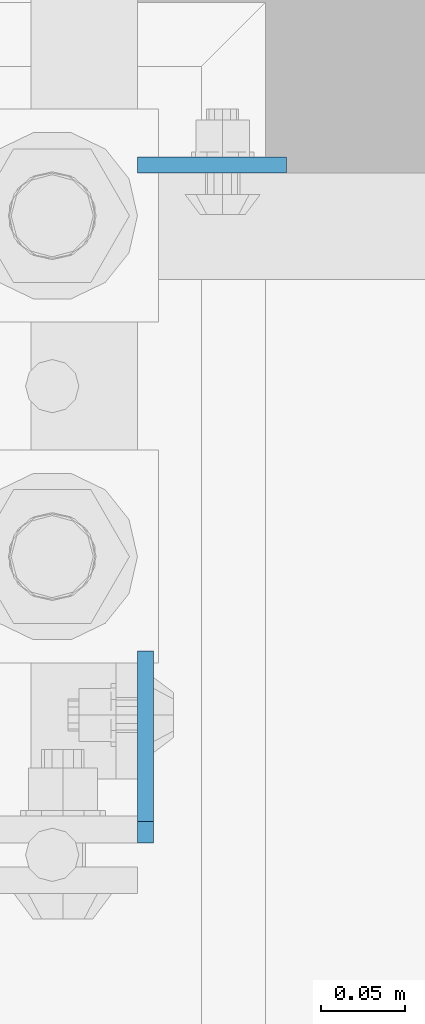
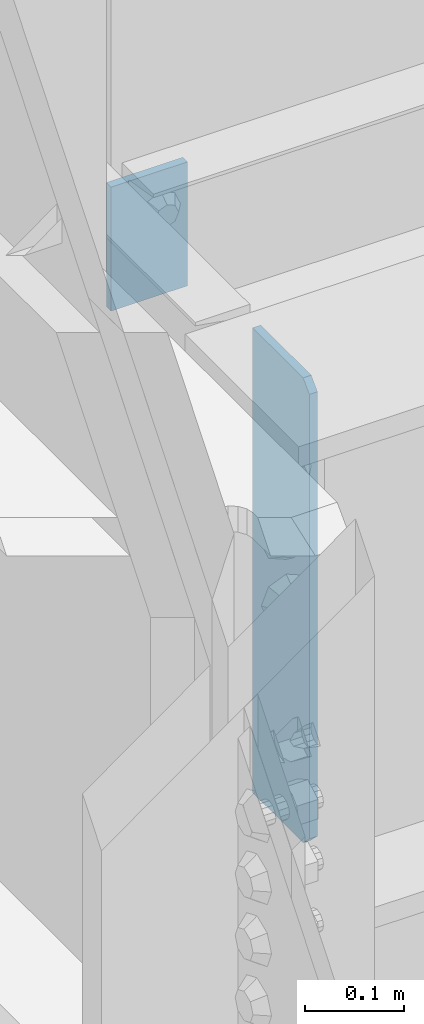
# One storey, part 1546 of 1876: 2 plates, 2 elements without a shape of their own.
"""IFC2X3 building model written with IfcOpenShell, lengths in millimetres."""

from ifc_helpers import new_model, si_unit, frame, origin_with_axes, place, context, subcontext, project, spatial, faceted_brep, material, type_object, element, aggregate, save


model = new_model("IFC2X3")

# Units and contexts
model_context = context("Model", 3, precision=1e-05, world=origin_with_axes())
body_context = subcontext(model_context, "Body", "Model", "MODEL_VIEW")
ifc_project = project(units=[si_unit("LENGTHUNIT", "METRE", prefix="MILLI"), si_unit("AREAUNIT", "SQUARE_METRE"), si_unit("VOLUMEUNIT", "CUBIC_METRE"), si_unit("MASSUNIT", "GRAM", prefix="KILO"), si_unit("TIMEUNIT", "SECOND"), si_unit("PLANEANGLEUNIT", "RADIAN"), si_unit("SOLIDANGLEUNIT", "STERADIAN"), si_unit("THERMODYNAMICTEMPERATUREUNIT", "DEGREE_CELSIUS"), si_unit("LUMINOUSINTENSITYUNIT", "LUMEN")], contexts=[model_context])

# Site, building, storey
site_placement = place(None, origin_with_axes())
site = spatial("IfcSite", under=ifc_project, at=site_placement, CompositionType="ELEMENT")
building_placement = place(site_placement, origin_with_axes())
building = spatial("IfcBuilding", under=site, at=building_placement, Name="Undefined", CompositionType="ELEMENT")
storey_placement = place(building_placement, origin_with_axes())
storey = spatial("IfcBuildingStorey", under=building, at=storey_placement, Name="Undefined", CompositionType="ELEMENT", Elevation=0.0)

# Assembly, plate
assembly_1_placement = place(storey_placement, origin_with_axes())
assembly_1 = element("IfcElementAssembly", 1, at=assembly_1_placement, inside=storey, Name="BEAM", AssemblyPlace="NOTDEFINED", PredefinedType="RIGID_FRAME")
ifc_material = material(Name="STEEL/A36")
plate_type_1 = type_object("IfcPlateType", PredefinedType="NOTDEFINED")
plate_1_placement = place(assembly_1_placement, frame((254.0, 1935.1625, 17957.8), z_axis=(1.0, 0.0, 0.0), x_axis=(0.0, 0.0, -1.0)))
plate_1 = element("IfcPlate", 2, at=plate_1_placement, type_object=plate_type_1, material=ifc_material, Name="PLATE", context=body_context, shape_type="Brep", body=[
    faceted_brep([(0.0, -4.76249999999982, 0.0), (0.0, -4.76249999999982, 88.9000015258789), (0.0, 4.76249999999982, 88.9000015258789), (0.0, 4.76249999999982, 0.0), (152.399993896484, -4.76249999999982, 88.9000015258789), (152.399993896484, 4.76249999999982, 88.9000015258789), (152.399993896484, -4.76249999999982, 0.0), (152.399993896484, 4.76249999999982, 0.0)], [[[0, 1, 2, 3]], [[1, 4, 5, 2]], [[4, 6, 7, 5]], [[6, 0, 3, 7]], [[5, 7, 3, 2]], [[6, 4, 1, 0]]]),
])
aggregate(assembly_1, [plate_1])

assembly_2_placement = place(storey_placement, origin_with_axes())
assembly_2 = element("IfcElementAssembly", 3, at=assembly_2_placement, inside=storey, Name="BEAM", AssemblyPlace="NOTDEFINED", PredefinedType="RIGID_FRAME")
plate_type_2 = type_object("IfcPlateType", PredefinedType="NOTDEFINED")
plate_2_placement = place(assembly_2_placement, frame((258.762999916077, 1531.14375, 17386.3), z_axis=(0.0, 0.0, 1.0), x_axis=(0.0, 1.0, 0.0)))
plate_2 = element("IfcPlate", 4, at=plate_2_placement, type_object=plate_type_2, material=ifc_material, Name="PLATE", context=body_context, shape_type="Brep", body=[
    faceted_brep([(3.7040990719106e-08, -4.76249999999982, 12.6999998092651), (0.0, -4.76250000000005, 558.800000190735), (0.0, 4.76250000000005, 558.800000190735), (3.70396264770534e-08, 4.76249999999982, 12.6999998092651), (12.6999998092651, -4.76250000000005, 571.5), (12.6999998092651, 4.76250000000005, 571.5), (114.300003051758, -4.76249999999999, 571.5), (114.300003051758, 4.76249999999999, 571.5), (114.300003051758, -4.76249999999999, 0.0), (114.300003051758, 4.76249999999999, 0.0), (12.699999809267, -4.76249999999754, 1.09139364212751e-11), (12.6999998092651, 4.76250000000255, 1.09139364212751e-11)], [[[0, 1, 2, 3]], [[1, 4, 5, 2]], [[4, 6, 7, 5]], [[6, 8, 9, 7]], [[8, 10, 11, 9]], [[10, 0, 3, 11]], [[5, 7, 9, 11, 3, 2]], [[10, 8, 6, 4, 1, 0]]]),
])
aggregate(assembly_2, [plate_2])

save(model, "model.ifc")
